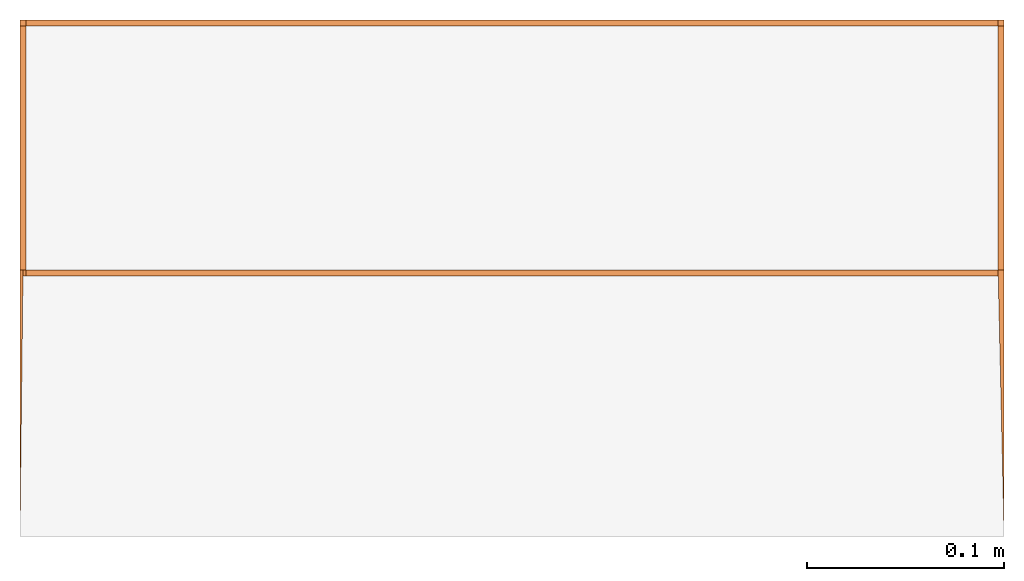
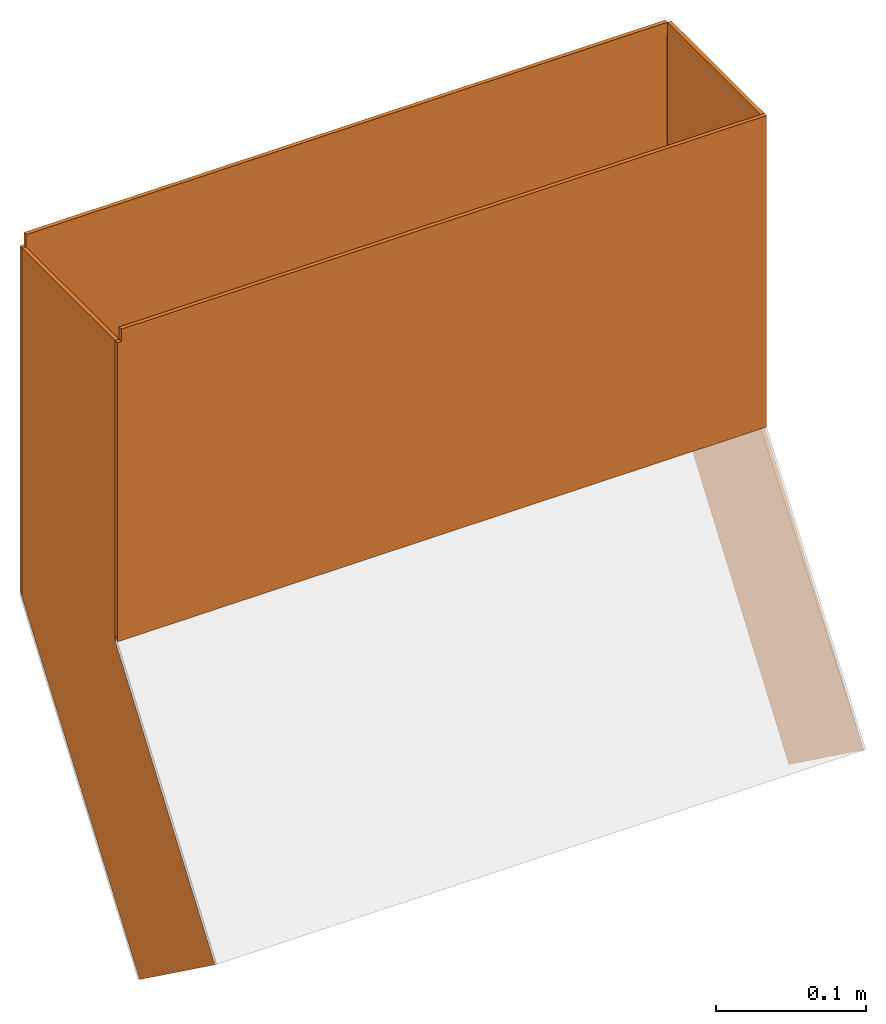
# One storey, part 2 of 2: 5 proxies.
"""IFC2X3 building model written with IfcOpenShell, lengths in metres."""

from ifc_helpers import new_model, entity, si_unit, converted_unit, derived_unit, money_unit, direction, frame, origin_with_axes, place, context, subcontext, project, spatial, polyline, outline, extrude, boolean, faceted_brep, material, type_object, element, save


model = new_model("IFC2X3")

# Units and contexts
model_context = context("Model", 3, precision=1e-05, world=origin_with_axes(), true_north=direction((0.0, 1.0)))
plan_context = context("Plan", 3, precision=1e-05, world=origin_with_axes(), true_north=direction((0.0, 1.0)))
body_context = subcontext(model_context, "Body", "Model", "MODEL_VIEW")
ifc_project = project(units=[si_unit("LENGTHUNIT", "METRE"), si_unit("AREAUNIT", "SQUARE_METRE"), si_unit("VOLUMEUNIT", "CUBIC_METRE"), converted_unit("PLANEANGLEUNIT", "DEGREE", entity("IfcPlaneAngleMeasure", 0.0174532925199), si_unit("PLANEANGLEUNIT", "RADIAN"), dimensions=[0, 0, 0, 0, 0, 0, 0]), si_unit("SOLIDANGLEUNIT", "STERADIAN"), money_unit("CHF"), converted_unit("TIMEUNIT", "Year", entity("IfcTimeMeasure", 31556926.0), si_unit("TIMEUNIT", "SECOND"), dimensions=[0, 0, 1, 0, 0, 0, 0]), si_unit("MASSUNIT", "GRAM", prefix="KILO"), si_unit("THERMODYNAMICTEMPERATUREUNIT", "DEGREE_CELSIUS"), si_unit("LUMINOUSINTENSITYUNIT", "LUMEN"), si_unit("ENERGYUNIT", "JOULE", prefix="MEGA"), derived_unit("THERMALCONDUCTANCEUNIT", [(si_unit("POWERUNIT", "WATT"), 1), (si_unit("LENGTHUNIT", "METRE"), -1), (si_unit("THERMODYNAMICTEMPERATUREUNIT", "KELVIN"), -1)]), derived_unit("SPECIFICHEATCAPACITYUNIT", [(si_unit("ENERGYUNIT", "JOULE"), 1), (si_unit("MASSUNIT", "GRAM", prefix="KILO"), -1), (si_unit("THERMODYNAMICTEMPERATUREUNIT", "KELVIN"), -1)]), derived_unit("MASSDENSITYUNIT", [(si_unit("MASSUNIT", "GRAM", prefix="KILO"), 1), (si_unit("VOLUMEUNIT", "CUBIC_METRE"), -1)])], contexts=[model_context, plan_context])

# Site, building, storey
site_placement = place(None, origin_with_axes())
site = spatial("IfcSite", under=ifc_project, at=site_placement, CompositionType="ELEMENT")
building_placement = place(site_placement, origin_with_axes())
building = spatial("IfcBuilding", under=site, at=building_placement, CompositionType="ELEMENT")
storey_placement = place(building_placement, frame((0.0, 0.0, -2.96), z_axis=(0.0, 0.0, 1.0), x_axis=(1.0, 0.0, 0.0)))
storey = spatial("IfcBuildingStorey", under=building, at=storey_placement, Name="UG01", CompositionType="ELEMENT", Elevation=-2.96)

# Proxies
ifc_material = material(Name="Metall, Stahl")
building_element_proxy_type_1 = type_object("IfcBuildingElementProxyType", Name="Metall, Stahl 3", PredefinedType="NOTDEFINED")
proxy_1_placement = place(storey_placement, frame((9.11522436818, 0.965872173005, 2.535), z_axis=(0.0, 0.0, 1.0), x_axis=(1.0, 0.0, 0.0)))
element("IfcBuildingElementProxy", 1, at=proxy_1_placement, inside=storey, type_object=building_element_proxy_type_1, material=ifc_material, Name="Wand-026", context=body_context, shape_type="CSG", body=[
    boolean("DIFFERENCE", boolean("DIFFERENCE", extrude(outline(polyline([(0.0, 0.0), (0.5, 0.0), (0.5, 0.003), (0.0, 0.003), (0.0, 0.0)])), origin_with_axes(), (0.0, 0.0, 1.0), 0.435), faceted_brep([(0.003, 0.0, 0.435), (0.003, 0.003, 0.435), (0.0, 0.003, 0.435), (0.0, 0.0, 0.435), (0.003, 0.003, 0.425), (0.003, 0.0, 0.425), (0.0, 0.003, 0.425), (0.0, 0.0, 0.425)], [[[0, 1, 2, 3]], [[4, 1, 0, 5]], [[4, 6, 2, 1]], [[6, 7, 3, 2]], [[5, 0, 3, 7]], [[6, 4, 5, 7]]])), faceted_brep([(1.96227034621e-10, 0.00299999974579, 0.18551039045), (0.500000000134, 0.00299999974579, 0.18551039045), (0.5, 0.003, 0.0), (0.0, 0.003, 0.0), (0.500000000134, 0.0, 0.181381245039), (1.96227034621e-10, 0.0, 0.181381245039), (0.5, 0.0, 0.0), (0.0, 0.0, 0.0)], [[[0, 1, 2, 3]], [[4, 1, 0, 5]], [[1, 4, 6, 2]], [[6, 7, 3, 2]], [[5, 0, 3, 7]], [[4, 5, 7, 6]]])),
])
proxy_2_placement = place(storey_placement, frame((9.61522436818, 0.965872173005, 2.535), z_axis=(0.0, 0.0, 1.0), x_axis=(0.0, 1.0, 0.0)))
element("IfcBuildingElementProxy", 2, at=proxy_2_placement, inside=storey, type_object=building_element_proxy_type_1, material=ifc_material, Name="Wand-027", context=body_context, shape_type="CSG", body=[
    boolean("DIFFERENCE", extrude(outline(polyline([(0.0, 0.0), (0.13, 0.0), (0.13, 0.003), (0.0, 0.003), (0.0, 0.0)])), origin_with_axes(), (0.0, 0.0, 1.0), 0.425), faceted_brep([(0.129999999746, 0.003, 0.14472378474), (0.129999999746, -1.33749011866e-10, 0.14472378474), (0.13, 0.0, 0.0), (0.13, 0.003, 0.0), (0.126999999771, -1.76727965595e-10, 0.140594639013), (0.126999999771, 0.00299999982327, 0.140594639013), (0.126999999771, -1.76727965595e-10, 0.425), (0.0, 0.0, 0.425), (0.0, 0.0, 0.0), (0.0, 0.003, 0.0), (0.0, 0.003, 0.425), (0.126999999771, 0.00299999982327, 0.425)], [[[0, 1, 2, 3]], [[4, 1, 0, 5]], [[4, 6, 7, 8, 2, 1]], [[2, 8, 9, 3]], [[5, 0, 3, 9, 10, 11]], [[11, 6, 4, 5]], [[6, 11, 10, 7]], [[10, 9, 8, 7]]])),
])
proxy_3_placement = place(storey_placement, frame((9.61522436818, 1.09587217301, 2.535), z_axis=(0.0, 0.0, 1.0), x_axis=(-1.0, 0.0, 0.0)))
element("IfcBuildingElementProxy", 3, at=proxy_3_placement, inside=storey, type_object=building_element_proxy_type_1, material=ifc_material, Name="Wand-028", context=body_context, shape_type="CSG", body=[
    boolean("DIFFERENCE", boolean("DIFFERENCE", extrude(outline(polyline([(0.0, 0.0), (0.5, 0.0), (0.5, 0.003), (0.0, 0.003), (0.0, 0.0)])), origin_with_axes(), (0.0, 0.0, 1.0), 0.435), faceted_brep([(0.497, 0.003, 0.435), (0.497, 0.0, 0.435), (0.5, 0.0, 0.435), (0.5, 0.003, 0.435), (0.497, 0.0, 0.425), (0.497, 0.003, 0.425), (0.5, 0.0, 0.425), (0.5, 0.003, 0.425)], [[[0, 1, 2, 3]], [[4, 1, 0, 5]], [[4, 6, 2, 1]], [[6, 7, 3, 2]], [[5, 0, 3, 7]], [[6, 4, 5, 7]]])), faceted_brep([(0.003, 2.54211762751e-10, 0.14472378474), (0.003, 0.0, 0.425), (0.003, 0.0, 0.435), (0.0, 0.0, 0.435), (0.0, 0.0, 0.0), (0.5, 0.0, 0.0), (0.499999999804, 2.54211762751e-10, 0.14472378474), (0.003, 0.003, 0.435), (0.003, 0.003, 0.140594639328), (0.0, 0.003, 0.435), (0.0, 0.003, 0.0), (0.5, 0.003, 0.0), (0.499999999804, 0.003, 0.140594639328)], [[[0, 1, 2, 3, 4, 5, 6]], [[7, 2, 1, 0, 8]], [[2, 7, 9, 3]], [[9, 10, 4, 3]], [[5, 4, 10, 11]], [[12, 6, 5, 11]], [[0, 6, 12, 8]], [[8, 12, 11, 10, 9, 7]]])),
])
building_element_proxy_type_2 = type_object("IfcBuildingElementProxyType", Name="Metall, Stahl", PredefinedType="NOTDEFINED")
proxy_4_placement = place(storey_placement, frame((1.76729741952e-10, 9.19330287884, 2.96), z_axis=(0.0, 0.0, 1.0), x_axis=(1.0, 0.0, 0.0)))
element("IfcBuildingElementProxy", 4, at=proxy_4_placement, inside=storey, type_object=building_element_proxy_type_2, material=ifc_material, Name="Wand-027", context=body_context, shape_type="Brep", body=[
    faceted_brep([(9.61222436818, -8.22443070606, -0.24462570871), (9.61222436818, -8.22443070606, 0.01), (9.61222436818, -8.10043070606, 0.01), (9.61222436818, -8.10043070606, -0.24462570871), (9.61522436818, -8.22443070606, -0.24462570871), (9.61522436818, -8.22443070606, 0.01), (9.61522436818, -8.10043070606, 0.01), (9.61522436818, -8.10043070606, -0.24462570871), (9.61522436818, -8.10043070606, -0.284915751472), (9.61522436857, -8.357484916, -0.427759118136), (9.61522436818, -8.2571357257, -0.500601707353)], [[[0, 1, 2, 3]], [[1, 0, 4, 5]], [[2, 1, 5, 6]], [[3, 2, 6, 7]], [[0, 3, 8]], [[4, 0, 9]], [[5, 4, 9, 10, 8, 7, 6]], [[3, 7, 8]], [[10, 0, 8]], [[0, 10, 9]]]),
])
proxy_5_placement = place(storey_placement, frame((1.76729741952e-10, 9.19330287884, 2.96), z_axis=(0.0, 0.0, 1.0), x_axis=(1.0, 0.0, 0.0)))
element("IfcBuildingElementProxy", 5, at=proxy_5_placement, inside=storey, type_object=building_element_proxy_type_2, material=ifc_material, Name="Wand-029", context=body_context, shape_type="Brep", body=[
    faceted_brep([(9.11522436818, -8.2571357257, -0.500601707353), (9.115224368, -8.357484916, -0.427759118136), (9.115224368, -8.22443070583, -0.244625708824), (9.11522436818, -8.22443070606, 0.0), (9.11522436818, -8.10043070606, 0.0), (9.11522436818, -8.10043070606, -0.284915751472), (9.11822436818, -8.10043070606, -0.244129145761), (9.11822436818, -8.22443070606, -0.244129145761), (9.11822436818, -8.22443070606, 0.0), (9.11822436818, -8.10043070606, 0.0)], [[[0, 1, 2, 3, 4, 5]], [[1, 0, 6]], [[2, 1, 6]], [[3, 2, 7, 8]], [[4, 3, 8, 9]], [[6, 5, 4, 9]], [[0, 5, 6]], [[7, 2, 6]], [[8, 7, 6, 9]]]),
])

save(model, "model.ifc")
